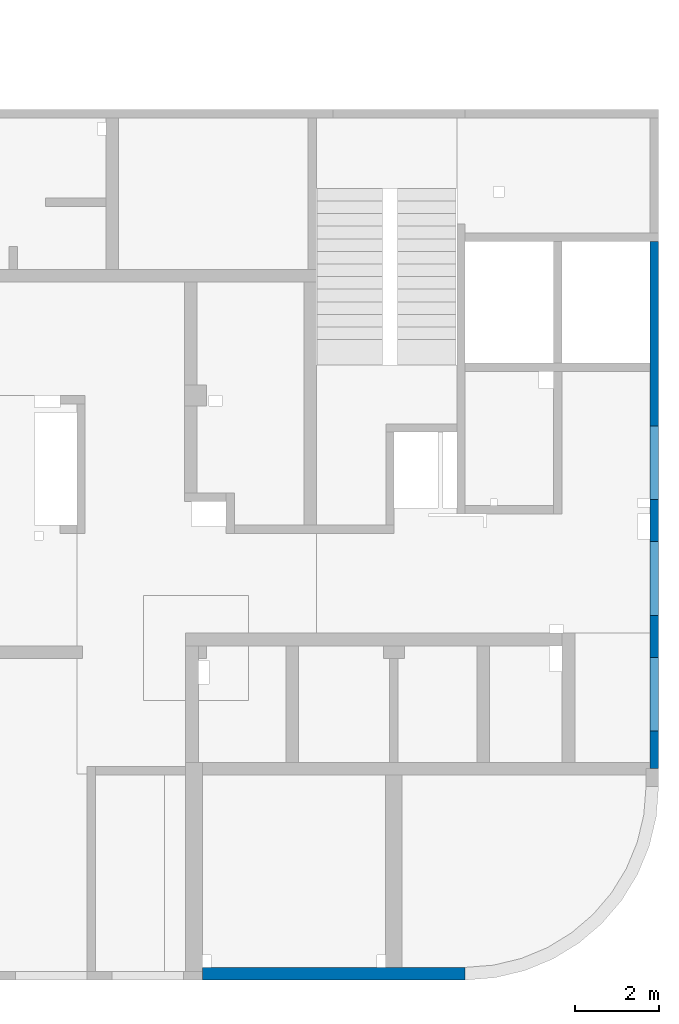
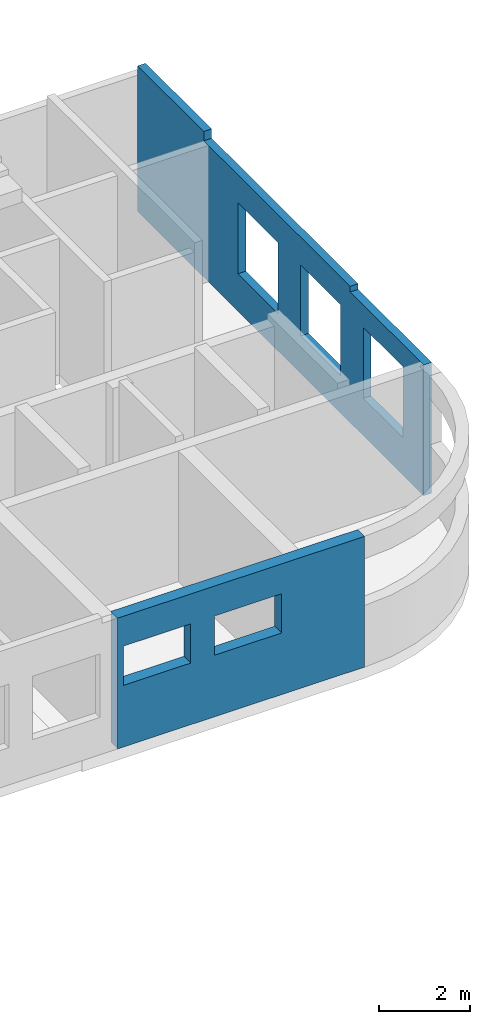
# One storey, part 10 of 10: 2 walls, 8 openings.
"""IFC4 building model written with IfcOpenShell, lengths in millimetres."""

from ifc_helpers import new_model, entity, si_unit, converted_unit, derived_unit, direction, frame, origin, place, context, subcontext, project, spatial, indexed_curve, outline, extrude, polygons, material, type_object, element, save


model = new_model("IFC4")

# Units and contexts
model_context = context("Model", 3, precision=0.01, world=origin(), true_north=direction((6.12303176911189e-17, 1.0)))
plan_context = context("Plan", 3, precision=0.01, world=origin(), true_north=direction((6.12303176911189e-17, 1.0)))
body_context = subcontext(model_context, "Body", "Model", "MODEL_VIEW")
ifc_project = project(units=[si_unit("LENGTHUNIT", "METRE", prefix="MILLI"), si_unit("AREAUNIT", "SQUARE_METRE"), si_unit("VOLUMEUNIT", "CUBIC_METRE"), converted_unit("PLANEANGLEUNIT", "DEGREE", entity("IfcRatioMeasure", 0.0174532925199433), si_unit("PLANEANGLEUNIT", "RADIAN"), dimensions=[0, 0, 0, 0, 0, 0, 0]), si_unit("MASSUNIT", "GRAM", prefix="KILO"), derived_unit("MASSDENSITYUNIT", [(si_unit("MASSUNIT", "GRAM", prefix="KILO"), 1), (si_unit("LENGTHUNIT", "METRE"), -3)]), derived_unit("MOMENTOFINERTIAUNIT", [(si_unit("LENGTHUNIT", "METRE"), 4)]), si_unit("TIMEUNIT", "SECOND"), si_unit("FREQUENCYUNIT", "HERTZ"), si_unit("THERMODYNAMICTEMPERATUREUNIT", "DEGREE_CELSIUS"), derived_unit("THERMALTRANSMITTANCEUNIT", [(si_unit("MASSUNIT", "GRAM", prefix="KILO"), 1), (si_unit("THERMODYNAMICTEMPERATUREUNIT", "KELVIN"), -1), (si_unit("TIMEUNIT", "SECOND"), -3)]), derived_unit("VOLUMETRICFLOWRATEUNIT", [(si_unit("LENGTHUNIT", "METRE"), 3), (si_unit("TIMEUNIT", "SECOND"), -1)]), derived_unit("MASSFLOWRATEUNIT", [(si_unit("MASSUNIT", "GRAM", prefix="KILO"), 1), (si_unit("TIMEUNIT", "SECOND"), -1)]), derived_unit("ROTATIONALFREQUENCYUNIT", [(si_unit("TIMEUNIT", "SECOND"), -1)]), si_unit("ELECTRICCURRENTUNIT", "AMPERE"), si_unit("ELECTRICVOLTAGEUNIT", "VOLT"), si_unit("POWERUNIT", "WATT"), si_unit("FORCEUNIT", "NEWTON", prefix="KILO"), si_unit("ILLUMINANCEUNIT", "LUX"), si_unit("LUMINOUSFLUXUNIT", "LUMEN"), si_unit("LUMINOUSINTENSITYUNIT", "CANDELA"), derived_unit("USERDEFINED", [(si_unit("MASSUNIT", "GRAM", prefix="KILO"), -1), (si_unit("LENGTHUNIT", "METRE"), -2), (si_unit("TIMEUNIT", "SECOND"), 3), (si_unit("LUMINOUSFLUXUNIT", "LUMEN"), 1)]), derived_unit("LINEARVELOCITYUNIT", [(si_unit("LENGTHUNIT", "METRE"), 1), (si_unit("TIMEUNIT", "SECOND"), -1)]), si_unit("PRESSUREUNIT", "PASCAL"), derived_unit("USERDEFINED", [(si_unit("LENGTHUNIT", "METRE"), -2), (si_unit("MASSUNIT", "GRAM", prefix="KILO"), 1), (si_unit("TIMEUNIT", "SECOND"), -2)]), derived_unit("LINEARFORCEUNIT", [(si_unit("MASSUNIT", "GRAM", prefix="KILO"), 1), (si_unit("LENGTHUNIT", "METRE"), 1), (si_unit("TIMEUNIT", "SECOND"), -2), (si_unit("LENGTHUNIT", "METRE"), -1)]), derived_unit("PLANARFORCEUNIT", [(si_unit("MASSUNIT", "GRAM", prefix="KILO"), 1), (si_unit("LENGTHUNIT", "METRE"), 1), (si_unit("TIMEUNIT", "SECOND"), -2), (si_unit("LENGTHUNIT", "METRE"), -2)])], contexts=[model_context, plan_context])

# Site, building, storey
site_placement = place(None, origin())
site = spatial("IfcSite", under=ifc_project, at=site_placement, CompositionType="ELEMENT")
building_placement = place(site_placement, origin())
building = spatial("IfcBuilding", under=site, at=building_placement, CompositionType="ELEMENT")
storey_placement = place(building_placement, frame((0.0, 0.0, 4200.0)))
storey = spatial("IfcBuildingStorey", under=building, at=storey_placement, CompositionType="ELEMENT", Elevation=4200.0)

# Wall, openings
ifc_material = material()
wall_type_1 = type_object("IfcWallType", PredefinedType="STANDARD")
wall_1_placement = place(storey_placement, frame((73470.0002685547, 17369.9992263554, -150.0), z_axis=(0.0, 0.0, 1.0), x_axis=(0.0, -1.0, 0.0)))
wall_1 = element("IfcWall", 1, at=wall_1_placement, inside=storey, type_object=wall_type_1, material=ifc_material, PredefinedType="NOTDEFINED", context=body_context, shape_type="Tessellation", body=[
    polygons([(9894.9999999995, -99.9999999999996, 2900.0), (11644.9999999995, -99.9999999999944, 2900.0), (11644.9999999995, -99.9999999999944, 1000.00000000001), (9894.9999999995, -99.9999999999996, 1000.00000000001), (7144.9999999995, -99.9999999999991, 2900.0), (8894.9999999995, -99.9999999999939, 2900.0), (8894.9999999995, -99.9999999999939, 1000.00000000001), (7144.9999999995, -99.9999999999991, 1000.00000000001), (4394.99999999951, -100.000000000007, 2900.0), (6144.9999999995, -100.000000000002, 2900.0), (6144.9999999995, -100.000000000002, 1000.00000000001), (4394.99999999951, -100.000000000007, 1000.00000000001), (0.0, -99.9999999999945, 5.41433564649196e-13), (2899.9999999995, -99.9999999999945, 5.41433564649196e-13), (3099.9999999995, -99.9999999999939, 5.41433564649196e-13), (6119.99999999898, -99.9999999999935, 5.41433564649196e-13), (6319.99999999899, -99.999999999993, 5.41433564649196e-13), (6484.99999999899, -99.9999999999925, 5.41433564649196e-13), (7084.99999999899, -99.9999999999907, 5.41433564649196e-13), (12394.9999999994, -99.9999999999921, 5.41433564649196e-13), (12544.9999999994, -99.9999999999917, 5.41433564649196e-13), (12544.9999999994, -99.9999999999917, 3500.0), (12394.9999999994, -99.9999999999921, 3500.0), (9319.99999999947, -99.9999999999927, 3500.0), (9319.99999999947, -99.9999999999927, 3650.0), (3099.9999999995, -99.9999999999939, 3650.0), (2899.99999999951, -99.9999999999945, 3650.0), (2899.99999999951, -99.9999999999945, 3900.0), (0.0, -99.9999999999945, 3900.0), (11644.9999999995, 100.000000000315, 2900.0), (9894.99999999951, 100.000000000327, 2900.0), (9894.99999999951, 100.000000000327, 1000.00000000001), (11644.9999999995, 100.000000000315, 1000.00000000001), (8894.9999999995, 100.000000000324, 2900.0), (7144.9999999995, 100.000000000328, 2900.0), (7144.9999999995, 100.000000000328, 1000.00000000001), (8894.9999999995, 100.000000000324, 1000.00000000001), (6144.99999999951, 100.000000000325, 2900.0), (4394.99999999951, 100.00000000032, 2900.0), (4394.99999999951, 100.00000000032, 1000.00000000001), (6144.99999999951, 100.000000000325, 1000.00000000001), (12544.9999999994, 100.000000000006, 5.41433564649196e-13), (9319.99999999947, 100.000000000005, 5.41433564649196e-13), (2899.99999999951, 100.000000000003, 5.41433564649196e-13), (0.0, 100.000000000003, 5.41433564649196e-13), (0.0, 100.000000000003, 3650.0), (0.0, 100.000000000003, 3900.0), (2899.99999999951, 100.000000000003, 3900.0), (2899.99999999951, 100.000000000003, 3650.0), (9319.99999999947, 99.9999999999965, 3650.0), (9319.99999999947, 99.9999999999965, 3500.0), (12544.9999999994, 100.000000000006, 3500.0)], [[[13, 14, 15, 16, 17, 18, 19, 20, 21, 22, 23, 24, 25, 26, 27, 28, 29], [1, 2, 3, 4], [5, 6, 7, 8], [9, 10, 11, 12]], [[42, 43, 44, 45, 46, 47, 48, 49, 50, 51, 52], [30, 31, 32, 33], [34, 35, 36, 37], [38, 39, 40, 41]], [[21, 20, 19, 18, 17, 16, 15, 14, 13, 45, 44, 43, 42]], [[47, 29, 28, 48]], [[21, 42, 52, 22]], [[49, 27, 26, 25, 50]], [[27, 49, 48, 28]], [[31, 30, 2, 1]], [[31, 1, 4, 32]], [[32, 4, 3, 33]], [[2, 30, 33, 3]], [[35, 34, 6, 5]], [[35, 5, 8, 36]], [[36, 8, 7, 37]], [[6, 34, 37, 7]], [[39, 38, 10, 9]], [[39, 9, 12, 40]], [[40, 12, 11, 41]], [[10, 38, 41, 11]], [[51, 24, 23, 22, 52]], [[24, 51, 50, 25]], [[45, 13, 29, 47, 46]]], closed=True),
])
opening_1_placement = place(wall_1_placement, origin())
element("IfcOpeningElement", 2, at=opening_1_placement, cuts=wall_1, PredefinedType="OPENING", context=body_context, shape_type="SweptSolid", body=[
    extrude(outline(indexed_curve([(-1449.99999999999, -874.999999999999), (1449.99999999999, -874.999999999999), (1449.99999999999, 875.0), (-1449.99999999999, 875.0), (-1449.99999999999, -874.999999999999)], self_intersect=False)), frame((10770.0, -100.000817871079, 5350.0), z_axis=(0.0, 1.0, 0.0), x_axis=(0.0, 0.0, -1.0)), (0.0, 0.0, 1.0), 200.000000000968),
])
opening_2_placement = place(wall_1_placement, origin())
element("IfcOpeningElement", 3, at=opening_2_placement, cuts=wall_1, PredefinedType="OPENING", context=body_context, shape_type="SweptSolid", body=[
    extrude(outline(indexed_curve([(-874.999999999999, -1449.99999999999), (874.999999999999, -1449.99999999999), (874.999999999999, 1450.0), (-874.999999999999, 1450.0), (-874.999999999999, -1449.99999999999)], self_intersect=False)), frame((8020.0, -100.00081787204, 5350.0), z_axis=(0.0, 1.0, 0.0), x_axis=(1.0, 0.0, 0.0)), (0.0, 0.0, 1.0), 200.000000000968),
])
opening_3_placement = place(wall_1_placement, origin())
element("IfcOpeningElement", 4, at=opening_3_placement, cuts=wall_1, PredefinedType="OPENING", context=body_context, shape_type="SweptSolid", body=[
    extrude(outline(indexed_curve([(-875.0, -1449.99999999999), (874.999999999998, -1449.99999999999), (874.999999999998, 1450.0), (-875.0, 1450.0), (-875.0, -1449.99999999999)], self_intersect=False)), frame((5270.0, -100.000817872048, 5350.0), z_axis=(0.0, 1.0, 0.0), x_axis=(1.0, 0.0, 0.0)), (0.0, 0.0, 1.0), 200.000000000968),
])
opening_4_placement = place(wall_1_placement, frame((17369.9992263554, -73470.0002685547, 150.0), z_axis=(0.0, 0.0, 1.0), x_axis=(0.0, 1.0, 0.0)))
element("IfcOpeningElement", 5, at=opening_4_placement, cuts=wall_1, PredefinedType="OPENING", context=body_context, shape_type="SweptSolid", body=[
    extrude(outline(indexed_curve([(-949.999999999993, -875.0), (949.999999999994, -875.0), (949.999999999994, 874.999999999999), (-949.999999999993, 874.999999999999), (-949.999999999993, -875.0)], self_intersect=False)), frame((73370.0002685546, 6599.99922635595, 1800.0), z_axis=(1.0, 0.0, 0.0), x_axis=(0.0, 0.0, -1.0)), (0.0, 0.0, 1.0), 200.000000000968),
])
opening_5_placement = place(wall_1_placement, frame((17369.9992263554, -73470.0002685547, 150.0), z_axis=(0.0, 0.0, 1.0), x_axis=(0.0, 1.0, 0.0)))
element("IfcOpeningElement", 6, at=opening_5_placement, cuts=wall_1, PredefinedType="OPENING", context=body_context, shape_type="SweptSolid", body=[
    extrude(outline(indexed_curve([(-949.999999999993, -874.999999999999), (949.999999999994, -874.999999999999), (949.999999999994, 875.0), (-949.999999999993, 875.0), (-949.999999999993, -874.999999999999)], self_intersect=False)), frame((73370.0002685546, 9349.99922635595, 1800.0), z_axis=(1.0, 0.0, 0.0), x_axis=(0.0, 0.0, -1.0)), (0.0, 0.0, 1.0), 200.000000000968),
])
opening_6_placement = place(wall_1_placement, frame((17369.9992263554, -73470.0002685547, 150.0), z_axis=(0.0, 0.0, 1.0), x_axis=(0.0, 1.0, 0.0)))
element("IfcOpeningElement", 7, at=opening_6_placement, cuts=wall_1, PredefinedType="OPENING", context=body_context, shape_type="SweptSolid", body=[
    extrude(outline(indexed_curve([(-949.999999999993, -875.0), (949.999999999994, -875.0), (949.999999999994, 875.0), (-949.999999999993, 875.0), (-949.999999999993, -875.0)], self_intersect=False)), frame((73370.0002685546, 12099.9992263559, 1800.0), z_axis=(1.0, 0.0, 0.0), x_axis=(0.0, 0.0, -1.0)), (0.0, 0.0, 1.0), 200.000000000968),
])

wall_type_2 = type_object("IfcWallType", PredefinedType="STANDARD")
wall_2_placement = place(storey_placement, frame((68969.9961987003, -50.000773643899, -150.0), z_axis=(0.0, 0.0, 1.0), x_axis=(-1.0, 0.0, 0.0)))
wall_2 = element("IfcWall", 8, at=wall_2_placement, inside=storey, type_object=wall_type_2, material=ifc_material, PredefinedType="NOTDEFINED", context=body_context, shape_type="Tessellation", body=[
    polygons([(-8.34067231120643e-12, -150.0, 3500.0), (3.22264723180709e-13, -150.0, 2900.0), (3.22264723180709e-13, -150.0, 1650.0), (-8.34067231120643e-12, -150.0, 5.41433564649196e-13), (1499.99593014566, -150.0, 5.41433564649196e-13), (1899.99593014565, -150.0, 5.41433564649196e-13), (2099.99593014566, -150.0, 5.41433564649196e-13), (6049.99593014566, -150.0, 5.41433564649196e-13), (6249.99593014565, -150.0, 5.41433564649196e-13), (6249.99593014565, -150.0, 3500.0), (1899.99593014565, -150.0, 3500.0), (1499.99593014566, -150.0, 3500.0), (4399.99593014561, -150.000000000321, 2700.0), (6099.99593014561, -150.000000000321, 2700.0), (6099.99593014561, -150.000000000321, 1650.00000000001), (4399.99593014561, -150.000000000321, 1650.00000000001), (2099.99593014561, -150.000000000321, 2700.0), (3799.99593014561, -150.000000000321, 2700.0), (3799.99593014561, -150.000000000321, 1650.00000000001), (2099.99593014561, -150.000000000321, 1650.00000000001), (-9.30747396035053e-12, 150.0, 5.41433564649196e-13), (-6.44536925963393e-13, 150.0, 1650.0), (-6.44536925963393e-13, 150.0, 2900.0), (-9.30747396035053e-12, 150.0, 3500.0), (6249.99593014565, 150.0, 3500.0), (6249.99593014565, 150.0, 5.41433564649196e-13), (6099.9959301456, 150.0, 2700.0), (4399.99593014561, 150.0, 2700.0), (4399.99593014561, 150.0, 1650.00000000001), (6099.9959301456, 150.0, 1650.00000000001), (3799.99593014561, 150.0, 2700.0), (2099.99593014561, 150.0, 2700.0), (2099.99593014561, 150.0, 1650.00000000001), (3799.99593014561, 150.0, 1650.00000000001), (6249.99593014565, -50.0, 5.41433564649196e-13), (6249.99593014565, -50.0000000000001, 3500.0)], [[[1, 2, 3, 4, 5, 6, 7, 8, 9, 10, 11, 12], [13, 14, 15, 16], [17, 18, 19, 20]], [[21, 22, 23, 24, 25, 26], [27, 28, 29, 30], [31, 32, 33, 34]], [[9, 8, 7, 6, 5, 4, 21, 26, 35]], [[1, 12, 11, 10, 36, 25, 24]], [[1, 24, 23, 22, 21, 4, 3, 2]], [[10, 9, 35, 26, 25, 36]], [[14, 13, 28, 27]], [[14, 27, 30, 15]], [[15, 30, 29, 16]], [[28, 13, 16, 29]], [[18, 17, 32, 31]], [[18, 31, 34, 19]], [[19, 34, 33, 20]], [[32, 17, 20, 33]]], closed=True),
])
opening_7_placement = place(wall_2_placement, frame((68969.9961987003, -50.000773643899, 150.0), z_axis=(0.0, 0.0, 1.0), x_axis=(-1.0, 0.0, 0.0)))
element("IfcOpeningElement", 9, at=opening_7_placement, cuts=wall_2, PredefinedType="OPENING", context=body_context, shape_type="SweptSolid", body=[
    extrude(outline(indexed_curve([(-849.999999999997, -524.999999999992), (850.000000000006, -524.999999999992), (850.000000000006, 524.999999999993), (-849.999999999997, 524.999999999993), (-849.999999999997, -524.999999999992)], self_intersect=False)), frame((66020.0002685547, 99.9992263570722, 2025.0), z_axis=(0.0, -1.0, 0.0), x_axis=(-1.0, 0.0, 0.0)), (0.0, 0.0, 1.0), 300.000000000962),
])
opening_8_placement = place(wall_2_placement, frame((68969.9961987003, -50.000773643899, 150.0), z_axis=(0.0, 0.0, 1.0), x_axis=(-1.0, 0.0, 0.0)))
element("IfcOpeningElement", 10, at=opening_8_placement, cuts=wall_2, PredefinedType="OPENING", context=body_context, shape_type="SweptSolid", body=[
    extrude(outline(indexed_curve([(-849.999999999997, -524.999999999992), (850.000000000006, -524.999999999992), (850.000000000006, 524.999999999993), (-849.999999999997, 524.999999999993), (-849.999999999997, -524.999999999992)], self_intersect=False)), frame((63720.0002685547, 99.9992263570796, 2025.0), z_axis=(0.0, -1.0, 0.0), x_axis=(-1.0, 0.0, 0.0)), (0.0, 0.0, 1.0), 300.000000000962),
])

save(model, "model.ifc")
